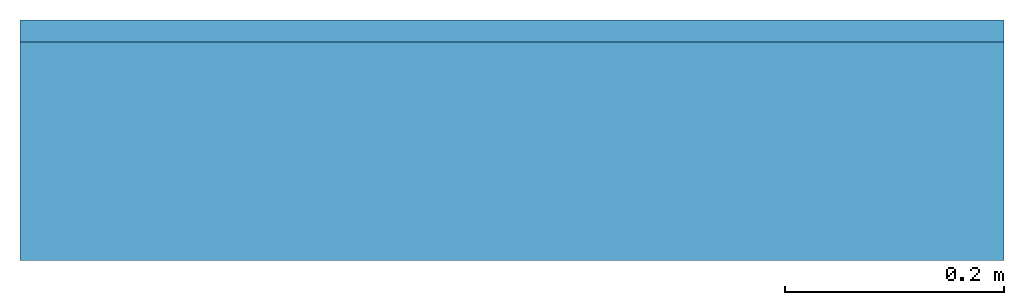
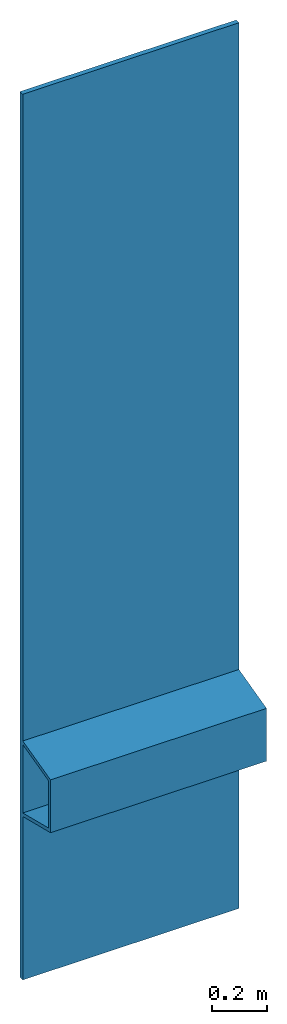
# Not in any storey: 1 beam.
"""IFC4 model written with IfcOpenShell, lengths in metres."""

from ifc_helpers import new_model, entity, si_unit, converted_unit, derived_unit, direction, frame, origin, place, context, subcontext, project, spatial, polyline, outline, extrude, source, transform, mapped, material, material_profile, profile_set, profile_usage, type_object, type_shapes, element, save


model = new_model("IFC4")

# Units and contexts
model_context = context("Model", 3, precision=1e-05, world=origin(), true_north=direction((6.12303176911189e-17, 1.0)))
body_context = subcontext(model_context, "Body", "Model", "MODEL_VIEW")
ifc_project = project(units=[si_unit("LENGTHUNIT", "METRE"), si_unit("AREAUNIT", "SQUARE_METRE"), si_unit("VOLUMEUNIT", "CUBIC_METRE"), converted_unit("PLANEANGLEUNIT", "DEGREE", entity("IfcRatioMeasure", 0.0174532925199433), si_unit("PLANEANGLEUNIT", "RADIAN"), dimensions=[0, 0, 0, 0, 0, 0, 0]), si_unit("MASSUNIT", "GRAM", prefix="KILO"), derived_unit("MASSDENSITYUNIT", [(si_unit("MASSUNIT", "GRAM", prefix="KILO"), 1), (si_unit("LENGTHUNIT", "METRE"), -3)]), derived_unit("MOMENTOFINERTIAUNIT", [(si_unit("LENGTHUNIT", "METRE"), 4)]), si_unit("TIMEUNIT", "SECOND"), si_unit("FREQUENCYUNIT", "HERTZ"), si_unit("THERMODYNAMICTEMPERATUREUNIT", "DEGREE_CELSIUS"), derived_unit("THERMALTRANSMITTANCEUNIT", [(si_unit("MASSUNIT", "GRAM", prefix="KILO"), 1), (si_unit("THERMODYNAMICTEMPERATUREUNIT", "KELVIN"), -1), (si_unit("TIMEUNIT", "SECOND"), -3)]), derived_unit("VOLUMETRICFLOWRATEUNIT", [(si_unit("LENGTHUNIT", "METRE"), 3), (si_unit("TIMEUNIT", "SECOND"), -1)]), si_unit("ELECTRICCURRENTUNIT", "AMPERE"), si_unit("ELECTRICVOLTAGEUNIT", "VOLT"), si_unit("POWERUNIT", "WATT"), si_unit("FORCEUNIT", "NEWTON", prefix="KILO"), si_unit("ILLUMINANCEUNIT", "LUX"), si_unit("LUMINOUSFLUXUNIT", "LUMEN"), si_unit("LUMINOUSINTENSITYUNIT", "CANDELA"), derived_unit("USERDEFINED", [(si_unit("MASSUNIT", "GRAM", prefix="KILO"), -1), (si_unit("LENGTHUNIT", "METRE"), -2), (si_unit("TIMEUNIT", "SECOND"), 3), (si_unit("LUMINOUSFLUXUNIT", "LUMEN"), 1)]), derived_unit("LINEARVELOCITYUNIT", [(si_unit("LENGTHUNIT", "METRE"), 1), (si_unit("TIMEUNIT", "SECOND"), -1)]), si_unit("PRESSUREUNIT", "PASCAL"), derived_unit("USERDEFINED", [(si_unit("LENGTHUNIT", "METRE"), -2), (si_unit("MASSUNIT", "GRAM", prefix="KILO"), 1), (si_unit("TIMEUNIT", "SECOND"), -2)]), derived_unit("LINEARFORCEUNIT", [(si_unit("MASSUNIT", "GRAM", prefix="KILO"), 1), (si_unit("LENGTHUNIT", "METRE"), 1), (si_unit("TIMEUNIT", "SECOND"), -2), (si_unit("LENGTHUNIT", "METRE"), -1)]), derived_unit("PLANARFORCEUNIT", [(si_unit("MASSUNIT", "GRAM", prefix="KILO"), 1), (si_unit("LENGTHUNIT", "METRE"), 1), (si_unit("TIMEUNIT", "SECOND"), -2), (si_unit("LENGTHUNIT", "METRE"), -2)])], contexts=[model_context])

# Site
site_placement = place(None, origin())
site = spatial("IfcSite", under=ifc_project, at=site_placement, CompositionType="ELEMENT")

# Beam
ifc_material = material(Name="Metall - Baustahl S355", Category="Metall")
ifc_material_profile = material_profile(ifc_material, outline(polyline([(-1.41806851403467, -0.0650000000000019), (2.48193148596533, -0.0650000000000019), (2.48193148596533, -0.0449999999999999), (-0.365819968104217, -0.044999999999999), (-0.415685568672853, 0.154999999999999), (-0.648177403257817, 0.155000000000001), (-0.698043003826451, -0.0449999999999988), (-1.41806851403467, -0.0449999999999988), (-1.41806851403467, -0.0650000000000019)]), holes=[polyline([(-0.381279172544464, -0.0450000000000004), (-0.682583799386203, -0.0449999999999991), (-0.636458118860216, 0.140000000000002), (-0.427404853070454, 0.140000000000002), (-0.381279172544464, -0.0450000000000004)])]), Name="Familie1")
ifc_profile_set = profile_set([ifc_material_profile], Name="Familie1")
ifc_profile_usage = profile_usage(ifc_profile_set, cardinal=8)
beam_type = type_object("IfcBeamType", Name="Familie1", PredefinedType="BEAM", material=ifc_profile_set)
shared_shape = source(origin(), body_context, "Body", "SweptSolid", [
    extrude(outline(polyline([(-1.41806851403467, -0.0650000000000019), (2.48193148596533, -0.0650000000000019), (2.48193148596533, -0.0449999999999999), (-0.365819968104217, -0.044999999999999), (-0.415685568672853, 0.154999999999999), (-0.648177403257817, 0.155000000000001), (-0.698043003826451, -0.0449999999999988), (-1.41806851403467, -0.0449999999999988), (-1.41806851403467, -0.0650000000000019)]), holes=[polyline([(-0.381279172544464, -0.0450000000000004), (-0.682583799386203, -0.0449999999999991), (-0.636458118860216, 0.140000000000002), (-0.427404853070454, 0.140000000000002), (-0.381279172544464, -0.0450000000000004)])]), frame((-0.45, -0.0550000000000023, 0.518068514034667), z_axis=(1.0, 0.0, 0.0), x_axis=(0.0, 0.0, 1.0)), (0.0, 0.0, 1.0), 0.9),
])
type_shapes(beam_type, [shared_shape])
beam_placement = place(site_placement, frame((1.06750670216995, -0.885758694013313, -1.05)))
element("IfcBeam", 1, at=beam_placement, inside=site, type_object=beam_type, material=ifc_profile_usage, Name="Familie1_Familie1", ObjectType="Familie1_Familie1", PredefinedType="BEAM", context=body_context, shape_type="MappedRepresentation", body=[
    mapped(shared_shape, transform((0.0, 0.0, 0.0), scale=1.0)),
])

save(model, "model.ifc")
